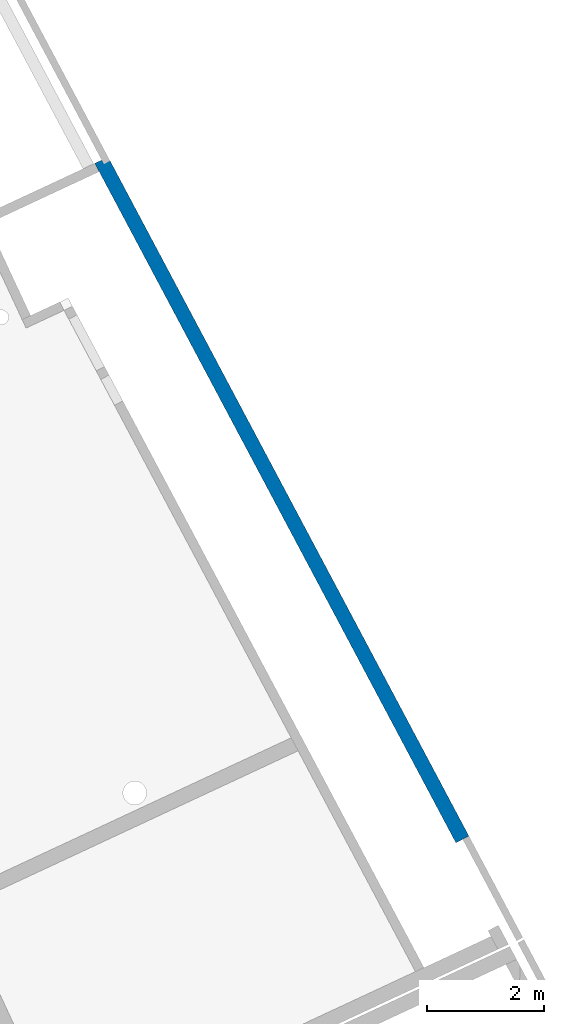
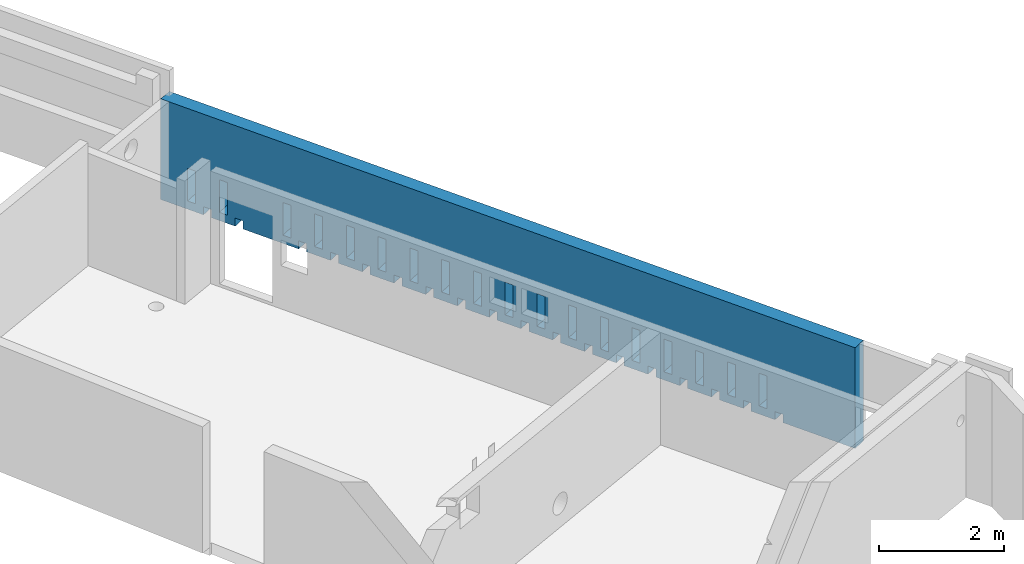
# One storey, part 12 of 13: 1 wall.
"""IFC2X3 building model written with IfcOpenShell, lengths in metres."""

import ifcopenshell
import ifcopenshell.guid

model = None  # the IFC model being written
_history = None  # IfcOwnerHistory: only IFC2X3 demands one
_inside = {}  # id of a spatial element -> (the spatial element, [elements in it])
_under = {}  # id of a project, library or spatial element -> (it, [spatial elements below it])
_declared = {}  # id of a project -> (the project, [libraries it declares])
_typed = {}  # id of a type object -> (the type object, [elements of that type])
_made_of = {}  # id of a material, layer set ... -> (it, [elements and type objects made of it])


def new_model(schema):
    """Start an empty IFC model of exactly this schema.

    Asked for "IFC4X3", IfcOpenShell would pick the latest addendum, in which some entities
    have other attributes; the version numbers below select the first issue.
    IFC2X3 requires an IfcOwnerHistory on every rooted entity: one is made here for all.
    """
    global model, _history
    if schema == "IFC4X3":
        model = ifcopenshell.file(schema_version=(4, 3, 0, 0))
    else:
        model = ifcopenshell.file(schema=schema)
    _inside.clear()
    _under.clear()
    _declared.clear()
    _typed.clear()
    _made_of.clear()
    _history = None
    if model.schema == "IFC2X3":
        org = make("IfcOrganization", Name="unknown")
        user = make(
            "IfcPersonAndOrganization",
            ThePerson=make("IfcPerson", FamilyName="unknown"),
            TheOrganization=org,
        )
        app = make(
            "IfcApplication",
            ApplicationDeveloper=org,
            Version="unknown",
            ApplicationFullName="unknown",
            ApplicationIdentifier="unknown",
        )
        _history = make(
            "IfcOwnerHistory",
            OwningUser=user,
            OwningApplication=app,
            ChangeAction="ADDED",
            CreationDate=0,
        )
    return model


def make(cls, **values):
    """One entity of the class cls with the attributes given. An attribute that is None is left unset."""
    return model.create_entity(
        cls, **{name: value for name, value in values.items() if value is not None}
    )


def entity(cls, *values):
    """Any entity or typed value of the class cls, its attributes in the order of the schema. None: left unset."""
    e = model.create_entity(cls)
    for i, value in enumerate(values):
        if value is not None:
            e[i] = value
    return e


def rooted(cls, **values):
    """An entity with a GlobalId (a new one), such as an element, a storey or a relation."""
    return make(cls, GlobalId=ifcopenshell.guid.new(), OwnerHistory=_history, **values)


def si_unit(unit_type, name, prefix=None):
    """IfcSIUnit, for example si_unit("LENGTHUNIT", "METRE", prefix="MILLI")."""
    return make("IfcSIUnit", UnitType=unit_type, Prefix=prefix, Name=name)


def converted_unit(unit_type, name, factor, base, dimensions=None, offset=None):
    """IfcConversionBasedUnit, such as the inch: factor (a typed value) times the base unit."""
    return make(
        "IfcConversionBasedUnit"
        if offset is None
        else "IfcConversionBasedUnitWithOffset",
        ConversionOffset=offset,
        Dimensions=None
        if dimensions is None
        else entity("IfcDimensionalExponents", *dimensions),
        UnitType=unit_type,
        Name=name,
        ConversionFactor=make(
            "IfcMeasureWithUnit", ValueComponent=factor, UnitComponent=base
        ),
    )


def derived_unit(unit_type, elements):
    """IfcDerivedUnit: a product of units, each with its exponent."""
    return make(
        "IfcDerivedUnit",
        Elements=[
            make("IfcDerivedUnitElement", Unit=unit, Exponent=power)
            for unit, power in elements
        ],
        UnitType=unit_type,
    )


def assignment(units):
    """IfcUnitAssignment: the units of a project."""
    return None if units is None else make("IfcUnitAssignment", Units=units)


def point(xyz):
    """IfcCartesianPoint."""
    return None if xyz is None else make("IfcCartesianPoint", Coordinates=xyz)


def direction(xyz):
    """IfcDirection."""
    return None if xyz is None else make("IfcDirection", DirectionRatios=xyz)


def frame(location, z_axis=None, x_axis=None):
    """IfcAxis2Placement3D, a coordinate frame: its origin and axes. An axis left out is left unset."""
    return make(
        "IfcAxis2Placement3D",
        Location=point(location),
        Axis=direction(z_axis),
        RefDirection=direction(x_axis),
    )


def origin():
    """The frame at (0, 0, 0) with its axes left unset."""
    return frame((0.0, 0.0, 0.0))


def place(relative_to, where):
    """IfcLocalPlacement: puts the frame where relative to a parent placement (None: the world)."""
    return make(
        "IfcLocalPlacement", PlacementRelTo=relative_to, RelativePlacement=where
    )


def context(
    kind, dimensions, precision=None, world=None, true_north=None, identifier=None
):
    """IfcGeometricRepresentationContext, for example the 3D "Model" context."""
    return make(
        "IfcGeometricRepresentationContext",
        ContextIdentifier=identifier,
        ContextType=kind,
        CoordinateSpaceDimension=dimensions,
        Precision=precision,
        WorldCoordinateSystem=world,
        TrueNorth=true_north,
    )


def subcontext(parent, identifier, kind, view, scale=None):
    """IfcGeometricRepresentationSubContext, for example "Body" below "Model"."""
    return make(
        "IfcGeometricRepresentationSubContext",
        ContextIdentifier=identifier,
        ContextType=kind,
        ParentContext=parent,
        TargetScale=scale,
        TargetView=view,
    )


def project(units=None, contexts=None):
    """IfcProject with its units and contexts."""
    return rooted(
        "IfcProject",
        Name="project",
        RepresentationContexts=contexts,
        UnitsInContext=assignment(units),
    )


def spatial(cls, under=None, at=None, **own):
    """A site, building, storey or space (cls), placed at a placement, below another one or the project."""
    s = rooted(cls, ObjectPlacement=at, **own)
    if under is not None:
        _under.setdefault(under.id(), (under, []))[1].append(s)
    return s


def faces_of(points, faces, orient=None, outer=None):
    """IfcFace entities. A face is a list of loops; a loop is a list of indices into points, from 0.

    orient and outer hold one flag for each loop. By default every Orientation is true, the
    first loop of a face is its IfcFaceOuterBound and the others are IfcFaceBound.
    """
    made = []
    for i, loops in enumerate(faces):
        bounds = []
        for j, loop in enumerate(loops):
            is_outer = j == 0 if outer is None else outer[i][j]
            bounds.append(
                make(
                    "IfcFaceOuterBound" if is_outer else "IfcFaceBound",
                    Bound=make("IfcPolyLoop", Polygon=[points[k] for k in loop]),
                    Orientation=True if orient is None else orient[i][j],
                )
            )
        made.append(make("IfcFace", Bounds=bounds))
    return made


def faceted_brep(points, faces, orient=None, outer=None, voids=None):
    """IfcFacetedBrep: a solid bounded by flat faces; with voids (closed shells), ...WithVoids."""
    shared = [point(p) for p in points]
    hull = make("IfcClosedShell", CfsFaces=faces_of(shared, faces, orient, outer))
    if voids is None:
        return make("IfcFacetedBrep", Outer=hull)
    return make(
        "IfcFacetedBrepWithVoids",
        Outer=hull,
        Voids=[
            make(cls, CfsFaces=faces_of(shared, fs, o, b)) for cls, fs, o, b in voids
        ],
    )


def shape(context_of_items, identifier, shape_type, items):
    """IfcShapeRepresentation: the items that make up one representation, for example the "Body"."""
    return make(
        "IfcShapeRepresentation",
        ContextOfItems=context_of_items,
        RepresentationIdentifier=identifier,
        RepresentationType=shape_type,
        Items=items,
    )


def material(Name=None, Category=None):
    """IfcMaterial."""
    return make("IfcMaterial", Name=Name, Category=Category)


def layer(
    of_material, thickness, ventilated=None, Name=None, Category=None, Priority=None
):
    """IfcMaterialLayer: one layer of a wall or slab, of a material (None: an air gap)."""
    return make(
        "IfcMaterialLayer",
        Material=of_material,
        LayerThickness=thickness,
        IsVentilated=ventilated,
        Name=Name,
        Category=Category,
        Priority=Priority,
    )


def layer_set(layers, Name=None):
    """IfcMaterialLayerSet."""
    return make("IfcMaterialLayerSet", MaterialLayers=layers, LayerSetName=Name)


def made_of(thing, what):
    """Note that an element or type object is made of a material, layer set ...; save() writes the relation."""
    if what is not None:
        _made_of.setdefault(what.id(), (what, []))[1].append(thing)
    return thing


def type_object(cls, material=None, **own):
    """A type object (cls), such as IfcWallType, which elements share."""
    return made_of(rooted(cls, **own), material)


def element(
    cls,
    number,
    at=None,
    inside=None,
    cuts=None,
    type_object=None,
    material=None,
    context=None,
    identifier="Body",
    shape_type=None,
    held_by="IfcProductDefinitionShape",
    body=None,
    shapes=None,
    **own,
):
    """One element of the class cls, such as IfcWall. Its Tag is "e" and its number.

    at: its placement. inside: the storey or other place that contains it. cuts: it is an
    opening in that element (IfcRelVoidsElement). A single representation is given by context,
    identifier, shape_type and body (its items); several are given by shapes. held_by: the class
    of the entity that holds the representations. save() writes the other relations.
    """
    e = rooted(cls, Tag="e%d" % number, ObjectPlacement=at, **own)
    if body is not None:
        shapes = [shape(context, identifier, shape_type, body)]
    if shapes is not None:
        e.Representation = make(held_by, Representations=shapes)
    if inside is not None:
        _inside.setdefault(inside.id(), (inside, []))[1].append(e)
    if cuts is not None:
        rooted(
            "IfcRelVoidsElement", RelatingBuildingElement=cuts, RelatedOpeningElement=e
        )
    if type_object is not None:
        _typed.setdefault(type_object.id(), (type_object, []))[1].append(e)
    return made_of(e, material)


def aggregate(whole, parts):
    """IfcRelAggregates: a whole, such as a stair, and the parts it consists of."""
    return rooted("IfcRelAggregates", RelatingObject=whole, RelatedObjects=parts)


def save(model, path):
    """Write the relations noted so far, then the file.

    IfcRelAggregates (storeys below a building ...), IfcRelContainedInSpatialStructure (elements
    in a storey), IfcRelDefinesByType, IfcRelAssociatesMaterial and IfcRelDeclares: one each for
    every whole, place, type object, material and project.
    """
    for whole, parts in _under.values():
        aggregate(whole, parts)
    for where, things in _inside.values():
        rooted(
            "IfcRelContainedInSpatialStructure",
            RelatedElements=things,
            RelatingStructure=where,
        )
    for kind, things in _typed.values():
        rooted("IfcRelDefinesByType", RelatedObjects=things, RelatingType=kind)
    for what, things in _made_of.values():
        rooted("IfcRelAssociatesMaterial", RelatedObjects=things, RelatingMaterial=what)
    for by, libraries in _declared.values():
        rooted("IfcRelDeclares", RelatingContext=by, RelatedDefinitions=libraries)
    model.write(path)


model = new_model("IFC2X3")

# Units and contexts
model_context = context("Model", 3, precision=1e-05, world=origin(), true_north=direction((6.12303176911189e-17, 1.0)))
body_context = subcontext(model_context, "Body", "Model", "MODEL_VIEW")
ifc_project = project(units=[si_unit("LENGTHUNIT", "METRE"), si_unit("AREAUNIT", "SQUARE_METRE"), si_unit("VOLUMEUNIT", "CUBIC_METRE"), converted_unit("PLANEANGLEUNIT", "DEGREE", entity("IfcRatioMeasure", 0.0174532925199433), si_unit("PLANEANGLEUNIT", "RADIAN"), dimensions=[0, 0, 0, 0, 0, 0, 0]), si_unit("MASSUNIT", "GRAM", prefix="KILO"), derived_unit("MASSDENSITYUNIT", [(si_unit("MASSUNIT", "GRAM", prefix="KILO"), 1), (si_unit("LENGTHUNIT", "METRE"), -3)]), si_unit("TIMEUNIT", "SECOND"), si_unit("FREQUENCYUNIT", "HERTZ"), si_unit("THERMODYNAMICTEMPERATUREUNIT", "DEGREE_CELSIUS"), derived_unit("THERMALTRANSMITTANCEUNIT", [(si_unit("MASSUNIT", "GRAM", prefix="KILO"), 1), (si_unit("THERMODYNAMICTEMPERATUREUNIT", "KELVIN"), -1), (si_unit("TIMEUNIT", "SECOND"), -3)]), derived_unit("VOLUMETRICFLOWRATEUNIT", [(si_unit("LENGTHUNIT", "METRE"), 3), (si_unit("TIMEUNIT", "SECOND"), -1)]), si_unit("ELECTRICCURRENTUNIT", "AMPERE"), si_unit("ELECTRICVOLTAGEUNIT", "VOLT"), si_unit("POWERUNIT", "WATT"), si_unit("FORCEUNIT", "NEWTON", prefix="KILO"), si_unit("ILLUMINANCEUNIT", "LUX"), si_unit("LUMINOUSFLUXUNIT", "LUMEN"), si_unit("LUMINOUSINTENSITYUNIT", "CANDELA"), derived_unit("USERDEFINED", [(si_unit("MASSUNIT", "GRAM", prefix="KILO"), -1), (si_unit("LENGTHUNIT", "METRE"), -2), (si_unit("TIMEUNIT", "SECOND"), 3), (si_unit("LUMINOUSFLUXUNIT", "LUMEN"), 1)]), derived_unit("LINEARVELOCITYUNIT", [(si_unit("LENGTHUNIT", "METRE"), 1), (si_unit("TIMEUNIT", "SECOND"), -1)]), si_unit("PRESSUREUNIT", "PASCAL"), derived_unit("USERDEFINED", [(si_unit("LENGTHUNIT", "METRE"), -2), (si_unit("MASSUNIT", "GRAM", prefix="KILO"), 1), (si_unit("TIMEUNIT", "SECOND"), -2)])], contexts=[model_context])

# Site, building, storey
site_placement = place(None, frame((5.36960000000003, 43.3158000000006, 0.0), z_axis=(0.0, 0.0, 1.0), x_axis=(-0.422618261740703, 0.906307787036648, 0.0)))
site = spatial("IfcSite", under=ifc_project, at=site_placement, CompositionType="ELEMENT")
building_placement = place(site_placement, origin())
building = spatial("IfcBuilding", under=site, at=building_placement, CompositionType="ELEMENT")
storey_placement = place(building_placement, frame((0.0, 0.0, 2.56)))
storey = spatial("IfcBuildingStorey", under=building, at=storey_placement, CompositionType="ELEMENT", Elevation=2.56)

# Wall
ifc_material = material(Name="C30/37 XS1")
ifc_layer = layer(ifc_material, 0.25)
ifc_layer_set = layer_set([ifc_layer])
wall_type = type_object("IfcWallType", PredefinedType="STANDARD", material=ifc_layer_set)
wall_placement = place(storey_placement, frame((22.3212803030831, 1.31624621228755, 0.0), z_axis=(0.0, 0.0, 1.0), x_axis=(0.998640817743407, 0.0521202181190781, 0.0)))
element("IfcWall", 1, at=wall_placement, inside=storey, type_object=wall_type, context=body_context, shape_type="Brep", body=[
    faceted_brep([(13.1112262227629, -0.125, 1.97), (0.0, -0.125, 1.97), (0.0, -0.125, 0.0), (1.36351429752506, -0.125, 0.0), (1.36351429752506, -0.125, 0.160000000000072), (1.5135142975257, -0.125, 0.160000000000072), (1.51351429752581, -0.125, 0.0), (1.96351429752604, -0.125, 0.0), (1.96351429752603, -0.125, 0.160000000000072), (2.11351429752657, -0.125, 0.160000000000072), (2.11351429752672, -0.125, 0.0), (2.56351429752711, -0.125, 0.0), (2.56351429752721, -0.125, 0.160000000000072), (2.71351429752696, -0.125, 0.160000000000072), (2.71351429752713, -0.125, 0.0), (3.163514297528, -0.125, 0.0), (3.16351429752808, -0.125, 0.160000000000055), (3.31351429752793, -0.125, 0.160000000000055), (3.31351429752811, -0.125, 0.0), (3.76351429752895, -0.125, 0.0), (3.76351429752895, -0.125, 0.160000000000055), (3.91351429752916, -0.125, 0.160000000000055), (3.91351429752929, -0.125, 0.0), (4.36351429752981, -0.125, 0.0), (4.36351429752981, -0.125, 0.160000000000055), (4.51351429753002, -0.125, 0.160000000000055), (4.51351429753019, -0.125, 0.0), (4.96351429752977, -0.125, 0.0), (4.96351429752977, -0.125, 0.160000000000055), (5.11351429753029, -0.125, 0.160000000000055), (5.11351429753051, -0.125, 0.0), (5.56351429753074, -0.125, 0.0), (5.56351429753074, -0.125, 0.160000000000055), (5.71351429753126, -0.125, 0.160000000000055), (5.71351429753135, -0.125, 0.0), (6.16351429753172, -0.125, 0.0), (6.16351429753171, -0.125, 0.160000000000055), (6.31351429753223, -0.125, 0.160000000000055), (6.31351429753234, -0.125, 0.0), (6.76351429753268, -0.125, 0.0), (6.76351429753268, -0.125, 0.160000000000055), (6.91351429753349, -0.125, 0.160000000000055), (6.91351429753368, -0.125, 0.0), (7.36351429753365, -0.125, 0.0), (7.36351429753365, -0.125, 0.160000000000055), (7.51351429753362, -0.125, 0.160000000000055), (7.51351429753375, -0.125, 0.0), (7.96351429753462, -0.125, 0.0), (7.96351429753462, -0.125, 0.160000000000055), (8.11351429753459, -0.125, 0.160000000000055), (8.11351429753474, -0.125, 0.0), (8.56351429753588, -0.125, 0.0), (8.56351429753587, -0.125, 0.160000000000055), (8.71351429753556, -0.125, 0.160000000000055), (8.71351429753571, -0.125, 0.0), (9.16351429753664, -0.125, 0.0), (9.16351429753674, -0.125, 0.160000000000055), (9.31351429753653, -0.125, 0.160000000000055), (9.3135142975367, -0.125, 0.0), (9.76351429753699, -0.125, 0.0), (9.76351429753698, -0.125, 0.160000000000055), (9.9135142975375, -0.125, 0.160000000000055), (9.91351429753768, -0.125, 0.0), (10.363514297538, -0.125, 0.0), (10.3635142975379, -0.125, 0.160000000000055), (10.5135142975387, -0.125, 0.160000000000055), (10.5135142975388, -0.125, 0.0), (11.5635142975382, -0.125, 0.0), (11.5635142975382, -0.125, 0.160000000000082), (11.7135142975382, -0.125, 0.160000000000082), (11.7135142975384, -0.125, 0.0), (12.1635142975391, -0.125, 0.0), (12.1635142975389, -0.125, 0.160000000000082), (12.3135142975392, -0.125, 0.160000000000082), (12.3135142975393, -0.125, 0.0), (13.1112262227629, -0.125, 0.0), (12.4637180675649, -0.125, 0.799999999999991), (12.6140604058233, -0.125, 0.799999999999991), (12.6140604058238, -0.125, 0.160000000000082), (12.463718067565, -0.125, 0.160000000000082), (11.8635142975384, -0.125, 0.79999999999999), (12.0135142975387, -0.125, 0.79999999999999), (12.013514297539, -0.125, 0.160000000000082), (11.863514297539, -0.125, 0.160000000000082), (10.6635142975384, -0.125, 0.799999999999965), (10.8135142975391, -0.125, 0.799999999999965), (10.8135142975398, -0.125, 0.160000000000055), (10.6635142975384, -0.125, 0.160000000000055), (10.0635142975375, -0.125, 0.79999999999996), (10.2135142975383, -0.125, 0.79999999999996), (10.2135142975387, -0.125, 0.160000000000055), (10.0635142975375, -0.125, 0.160000000000055), (9.46351429753649, -0.125, 0.799999999999958), (9.61351429753701, -0.125, 0.799999999999958), (9.61351429753772, -0.125, 0.160000000000055), (9.46351429753649, -0.125, 0.160000000000055), (8.8635142975363, -0.125, 0.799999999999956), (9.01351429753605, -0.125, 0.799999999999956), (9.0135142975367, -0.125, 0.160000000000055), (8.86351429753582, -0.125, 0.160000000000055), (8.2635142975351, -0.125, 0.799999999999954), (8.41351429753508, -0.125, 0.799999999999954), (8.41351429753568, -0.125, 0.160000000000055), (8.2635142975351, -0.125, 0.160000000000055), (7.66351429753414, -0.125, 0.799999999999951), (7.8135142975341, -0.125, 0.799999999999951), (7.81351429753466, -0.125, 0.160000000000055), (7.66351429753414, -0.125, 0.160000000000055), (7.06351429753317, -0.125, 0.799999999999949), (7.21351429753313, -0.125, 0.799999999999949), (7.21351429753363, -0.125, 0.160000000000055), (7.06351429753317, -0.125, 0.160000000000055), (6.46351429753219, -0.125, 0.799999999999947), (6.61351429753271, -0.125, 0.799999999999947), (6.61351429753317, -0.125, 0.160000000000055), (6.46351429753219, -0.125, 0.160000000000055), (5.86351429753122, -0.125, 0.799999999999945), (6.01351429753174, -0.125, 0.799999999999945), (6.01351429753215, -0.125, 0.160000000000055), (5.86351429753122, -0.125, 0.160000000000055), (5.26351429753025, -0.125, 0.799999999999943), (5.41351429753078, -0.125, 0.799999999999943), (5.41351429753112, -0.125, 0.160000000000055), (5.26351429753025, -0.125, 0.160000000000055), (4.66351429753062, -0.125, 0.799999999999941), (4.81351429753046, -0.125, 0.799999999999941), (4.81351429753121, -0.125, 0.160000000000055), (4.66351429753024, -0.125, 0.160000000000055), (4.06351429752938, -0.125, 0.799999999999938), (4.21351429752959, -0.125, 0.799999999999938), (4.21351429753019, -0.125, 0.160000000000055), (4.06351429752938, -0.125, 0.160000000000055), (3.46351429752852, -0.125, 0.799999999999936), (3.61351429752842, -0.125, 0.799999999999936), (3.61351429752917, -0.125, 0.160000000000055), (3.46351429752852, -0.125, 0.160000000000055), (2.86351429752765, -0.125, 0.799999999999934), (3.01351429752745, -0.125, 0.799999999999934), (3.01351429752814, -0.125, 0.160000000000055), (2.86351429752726, -0.125, 0.160000000000055), (2.26351429752678, -0.125, 0.799999999999932), (2.413514297527, -0.125, 0.799999999999932), (2.41351429752767, -0.125, 0.160000000000072), (2.26351429752624, -0.125, 0.160000000000072), (1.66351429752554, -0.125, 0.79999999999993), (1.81351429752613, -0.125, 0.79999999999993), (1.81351429752666, -0.125, 0.160000000000072), (1.66351429752554, -0.125, 0.160000000000072), (12.4637180675648, 0.125, 0.799999999999991), (12.463718067565, 0.125, 0.160000000000082), (12.6140604058238, 0.125, 0.160000000000082), (12.6140604058233, 0.125, 0.799999999999991), (12.3135142975392, 0.125, 0.160000000000082), (12.1635142975389, 0.125, 0.160000000000082), (12.1635142975391, 0.125, 0.0), (11.7135142975384, 0.125, 0.0), (11.7135142975382, 0.125, 0.160000000000082), (11.5635142975382, 0.125, 0.160000000000082), (11.5635142975382, 0.125, 0.0), (10.5135142975388, 0.125, 0.0), (10.5135142975387, 0.125, 0.160000000000055), (10.3635142975379, 0.125, 0.160000000000055), (10.3635142975379, 0.125, 0.0), (9.91351429753769, 0.125, 0.0), (9.91351429753749, 0.125, 0.160000000000055), (9.76351429753698, 0.125, 0.160000000000055), (9.76351429753698, 0.125, 0.0), (9.3135142975367, 0.125, 0.0), (9.31351429753652, 0.125, 0.160000000000055), (9.16351429753673, 0.125, 0.160000000000055), (9.16351429753663, 0.125, 0.0), (8.71351429753571, 0.125, 0.0), (8.71351429753555, 0.125, 0.160000000000055), (8.56351429753587, 0.125, 0.160000000000055), (8.56351429753587, 0.125, 0.0), (8.11351429753474, 0.125, 0.0), (8.11351429753458, 0.125, 0.160000000000055), (7.96351429753461, 0.125, 0.160000000000055), (7.96351429753461, 0.125, 0.0), (7.51351429753375, 0.125, 0.0), (7.51351429753361, 0.125, 0.160000000000055), (7.36351429753364, 0.125, 0.160000000000055), (7.36351429753364, 0.125, 0.0), (6.91351429753369, 0.125, 0.0), (6.91351429753349, 0.125, 0.160000000000055), (6.76351429753268, 0.125, 0.160000000000055), (6.76351429753268, 0.125, 0.0), (6.31351429753234, 0.125, 0.0), (6.31351429753223, 0.125, 0.160000000000055), (6.16351429753171, 0.125, 0.160000000000055), (6.16351429753171, 0.125, 0.0), (5.71351429753135, 0.125, 0.0), (5.71351429753125, 0.125, 0.160000000000055), (5.56351429753073, 0.125, 0.160000000000055), (5.56351429753073, 0.125, 0.0), (5.11351429753051, 0.125, 0.0), (5.11351429753028, 0.125, 0.160000000000055), (4.96351429752976, 0.125, 0.160000000000055), (4.96351429752976, 0.125, 0.0), (4.51351429753019, 0.125, 0.0), (4.51351429753002, 0.125, 0.160000000000055), (4.3635142975298, 0.125, 0.160000000000055), (4.3635142975298, 0.125, 0.0), (3.91351429752929, 0.125, 0.0), (3.91351429752915, 0.125, 0.160000000000055), (3.76351429752894, 0.125, 0.160000000000055), (3.76351429752894, 0.125, 0.0), (3.31351429752811, 0.125, 0.0), (3.31351429752793, 0.125, 0.160000000000055), (3.16351429752807, 0.125, 0.160000000000055), (3.16351429752799, 0.125, 0.0), (2.71351429752713, 0.125, 0.0), (2.71351429752696, 0.125, 0.160000000000072), (2.56351429752721, 0.125, 0.160000000000072), (2.5635142975271, 0.125, 0.0), (2.11351429752672, 0.125, 0.0), (2.11351429752656, 0.125, 0.160000000000072), (1.96351429752602, 0.125, 0.160000000000072), (1.96351429752602, 0.125, 0.0), (1.51351429752581, 0.125, 0.0), (1.51351429752569, 0.125, 0.160000000000072), (1.36351429752505, 0.125, 0.160000000000072), (1.36351429752505, 0.125, 0.0), (0.0, 0.125, 0.0), (0.0, 0.125, 1.97), (12.9640562464722, 0.125, 1.97), (13.1242740116158, 0.125, 1.97), (13.1242740116158, 0.125, 0.0), (12.3135142975393, 0.125, 0.0), (11.8635142975384, 0.125, 0.79999999999999), (11.863514297539, 0.125, 0.160000000000082), (12.013514297539, 0.125, 0.160000000000082), (12.0135142975387, 0.125, 0.79999999999999), (10.6635142975384, 0.125, 0.799999999999965), (10.6635142975384, 0.125, 0.160000000000055), (10.8135142975398, 0.125, 0.160000000000055), (10.8135142975391, 0.125, 0.799999999999965), (10.0635142975375, 0.125, 0.79999999999996), (10.0635142975375, 0.125, 0.160000000000055), (10.2135142975387, 0.125, 0.160000000000055), (10.2135142975382, 0.125, 0.79999999999996), (9.46351429753649, 0.125, 0.799999999999958), (9.46351429753649, 0.125, 0.160000000000055), (9.61351429753772, 0.125, 0.160000000000055), (9.61351429753701, 0.125, 0.799999999999958), (8.8635142975363, 0.125, 0.799999999999956), (8.86351429753581, 0.125, 0.160000000000055), (9.0135142975367, 0.125, 0.160000000000055), (9.01351429753604, 0.125, 0.799999999999956), (8.2635142975351, 0.125, 0.799999999999954), (8.2635142975351, 0.125, 0.160000000000055), (8.41351429753567, 0.125, 0.160000000000055), (8.41351429753507, 0.125, 0.799999999999954), (7.66351429753413, 0.125, 0.799999999999951), (7.66351429753413, 0.125, 0.160000000000055), (7.81351429753466, 0.125, 0.160000000000055), (7.8135142975341, 0.125, 0.799999999999951), (7.06351429753316, 0.125, 0.799999999999949), (7.06351429753316, 0.125, 0.160000000000055), (7.21351429753363, 0.125, 0.160000000000055), (7.21351429753312, 0.125, 0.799999999999949), (6.46351429753219, 0.125, 0.799999999999947), (6.46351429753219, 0.125, 0.160000000000055), (6.61351429753316, 0.125, 0.160000000000055), (6.61351429753271, 0.125, 0.799999999999947), (5.86351429753122, 0.125, 0.799999999999945), (5.86351429753122, 0.125, 0.160000000000055), (6.01351429753214, 0.125, 0.160000000000055), (6.01351429753174, 0.125, 0.799999999999945), (5.26351429753025, 0.125, 0.799999999999943), (5.26351429753025, 0.125, 0.160000000000055), (5.41351429753112, 0.125, 0.160000000000055), (5.41351429753078, 0.125, 0.799999999999943), (4.66351429753061, 0.125, 0.799999999999941), (4.66351429753024, 0.125, 0.160000000000055), (4.81351429753121, 0.125, 0.160000000000055), (4.81351429753046, 0.125, 0.799999999999941), (4.06351429752937, 0.125, 0.799999999999938), (4.06351429752937, 0.125, 0.160000000000055), (4.21351429753019, 0.125, 0.160000000000055), (4.21351429752959, 0.125, 0.799999999999938), (3.46351429752851, 0.125, 0.799999999999936), (3.46351429752851, 0.125, 0.160000000000055), (3.61351429752917, 0.125, 0.160000000000055), (3.61351429752841, 0.125, 0.799999999999936), (2.86351429752764, 0.125, 0.799999999999934), (2.86351429752725, 0.125, 0.160000000000055), (3.01351429752814, 0.125, 0.160000000000055), (3.01351429752744, 0.125, 0.799999999999934), (2.26351429752678, 0.125, 0.799999999999932), (2.26351429752624, 0.125, 0.160000000000072), (2.41351429752767, 0.125, 0.160000000000072), (2.41351429752699, 0.125, 0.799999999999932), (1.66351429752554, 0.125, 0.79999999999993), (1.66351429752554, 0.125, 0.160000000000072), (1.81351429752666, 0.125, 0.160000000000072), (1.81351429752613, 0.125, 0.79999999999993), (0.0, -0.00499999999987975, 1.97)], [[[0, 1, 2, 3, 4, 5, 6, 7, 8, 9, 10, 11, 12, 13, 14, 15, 16, 17, 18, 19, 20, 21, 22, 23, 24, 25, 26, 27, 28, 29, 30, 31, 32, 33, 34, 35, 36, 37, 38, 39, 40, 41, 42, 43, 44, 45, 46, 47, 48, 49, 50, 51, 52, 53, 54, 55, 56, 57, 58, 59, 60, 61, 62, 63, 64, 65, 66, 67, 68, 69, 70, 71, 72, 73, 74, 75], [76, 77, 78, 79], [80, 81, 82, 83], [84, 85, 86, 87], [88, 89, 90, 91], [92, 93, 94, 95], [96, 97, 98, 99], [100, 101, 102, 103], [104, 105, 106, 107], [108, 109, 110, 111], [112, 113, 114, 115], [116, 117, 118, 119], [120, 121, 122, 123], [124, 125, 126, 127], [128, 129, 130, 131], [132, 133, 134, 135], [136, 137, 138, 139], [140, 141, 142, 143], [144, 145, 146, 147]], [[148, 149, 150, 151], [152, 153, 154, 155, 156, 157, 158, 159, 160, 161, 162, 163, 164, 165, 166, 167, 168, 169, 170, 171, 172, 173, 174, 175, 176, 177, 178, 179, 180, 181, 182, 183, 184, 185, 186, 187, 188, 189, 190, 191, 192, 193, 194, 195, 196, 197, 198, 199, 200, 201, 202, 203, 204, 205, 206, 207, 208, 209, 210, 211, 212, 213, 214, 215, 216, 217, 218, 219, 220, 221, 222, 223, 224, 225, 226, 227, 228], [229, 230, 231, 232], [233, 234, 235, 236], [237, 238, 239, 240], [241, 242, 243, 244], [245, 246, 247, 248], [249, 250, 251, 252], [253, 254, 255, 256], [257, 258, 259, 260], [261, 262, 263, 264], [265, 266, 267, 268], [269, 270, 271, 272], [273, 274, 275, 276], [277, 278, 279, 280], [281, 282, 283, 284], [285, 286, 287, 288], [289, 290, 291, 292], [293, 294, 295, 296]], [[1, 0, 226, 225, 224, 297]], [[297, 224, 223, 2, 1]], [[77, 76, 148, 151]], [[78, 77, 151, 150]], [[79, 78, 150, 149]], [[76, 79, 149, 148]], [[73, 72, 153, 152]], [[73, 152, 228, 74]], [[153, 72, 71, 154]], [[81, 80, 229, 232]], [[82, 81, 232, 231]], [[83, 82, 231, 230]], [[80, 83, 230, 229]], [[69, 68, 157, 156]], [[69, 156, 155, 70]], [[157, 68, 67, 158]], [[85, 84, 233, 236]], [[86, 85, 236, 235]], [[87, 86, 235, 234]], [[84, 87, 234, 233]], [[65, 64, 161, 160]], [[65, 160, 159, 66]], [[161, 64, 63, 162]], [[89, 88, 237, 240]], [[90, 89, 240, 239]], [[91, 90, 239, 238]], [[88, 91, 238, 237]], [[61, 60, 165, 164]], [[61, 164, 163, 62]], [[165, 60, 59, 166]], [[93, 92, 241, 244]], [[94, 93, 244, 243]], [[95, 94, 243, 242]], [[92, 95, 242, 241]], [[57, 56, 169, 168]], [[57, 168, 167, 58]], [[169, 56, 55, 170]], [[97, 96, 245, 248]], [[98, 97, 248, 247]], [[99, 98, 247, 246]], [[96, 99, 246, 245]], [[53, 52, 173, 172]], [[53, 172, 171, 54]], [[173, 52, 51, 174]], [[101, 100, 249, 252]], [[102, 101, 252, 251]], [[103, 102, 251, 250]], [[100, 103, 250, 249]], [[49, 48, 177, 176]], [[49, 176, 175, 50]], [[177, 48, 47, 178]], [[105, 104, 253, 256]], [[106, 105, 256, 255]], [[107, 106, 255, 254]], [[104, 107, 254, 253]], [[45, 44, 181, 180]], [[45, 180, 179, 46]], [[181, 44, 43, 182]], [[109, 108, 257, 260]], [[110, 109, 260, 259]], [[111, 110, 259, 258]], [[108, 111, 258, 257]], [[41, 40, 185, 184]], [[41, 184, 183, 42]], [[185, 40, 39, 186]], [[113, 112, 261, 264]], [[114, 113, 264, 263]], [[115, 114, 263, 262]], [[112, 115, 262, 261]], [[37, 36, 189, 188]], [[37, 188, 187, 38]], [[189, 36, 35, 190]], [[117, 116, 265, 268]], [[118, 117, 268, 267]], [[119, 118, 267, 266]], [[116, 119, 266, 265]], [[33, 32, 193, 192]], [[33, 192, 191, 34]], [[193, 32, 31, 194]], [[121, 120, 269, 272]], [[122, 121, 272, 271]], [[123, 122, 271, 270]], [[120, 123, 270, 269]], [[29, 28, 197, 196]], [[29, 196, 195, 30]], [[197, 28, 27, 198]], [[125, 124, 273, 276]], [[126, 125, 276, 275]], [[127, 126, 275, 274]], [[124, 127, 274, 273]], [[25, 24, 201, 200]], [[25, 200, 199, 26]], [[201, 24, 23, 202]], [[129, 128, 277, 280]], [[130, 129, 280, 279]], [[131, 130, 279, 278]], [[128, 131, 278, 277]], [[21, 20, 205, 204]], [[21, 204, 203, 22]], [[205, 20, 19, 206]], [[133, 132, 281, 284]], [[134, 133, 284, 283]], [[135, 134, 283, 282]], [[132, 135, 282, 281]], [[17, 16, 209, 208]], [[17, 208, 207, 18]], [[209, 16, 15, 210]], [[137, 136, 285, 288]], [[138, 137, 288, 287]], [[139, 138, 287, 286]], [[136, 139, 286, 285]], [[13, 12, 213, 212]], [[13, 212, 211, 14]], [[213, 12, 11, 214]], [[141, 140, 289, 292]], [[142, 141, 292, 291]], [[143, 142, 291, 290]], [[140, 143, 290, 289]], [[9, 8, 217, 216]], [[9, 216, 215, 10]], [[217, 8, 7, 218]], [[145, 144, 293, 296]], [[146, 145, 296, 295]], [[147, 146, 295, 294]], [[144, 147, 294, 293]], [[5, 4, 221, 220]], [[5, 220, 219, 6]], [[221, 4, 3, 222]], [[226, 0, 75, 227]], [[75, 74, 228, 227]], [[71, 70, 155, 154]], [[67, 66, 159, 158]], [[63, 62, 163, 162]], [[59, 58, 167, 166]], [[55, 54, 171, 170]], [[51, 50, 175, 174]], [[47, 46, 179, 178]], [[43, 42, 183, 182]], [[39, 38, 187, 186]], [[35, 34, 191, 190]], [[31, 30, 195, 194]], [[27, 26, 199, 198]], [[23, 22, 203, 202]], [[19, 18, 207, 206]], [[15, 14, 211, 210]], [[11, 10, 215, 214]], [[7, 6, 219, 218]], [[3, 2, 223, 222]]], outer=[[True, False, False, False, False, False, False, False, False, False, False, False, False, False, False, False, False, False, False], [False, True, False, False, False, False, False, False, False, False, False, False, False, False, False, False, False, False, False], [True], [True], [True], [True], [True], [True], [True], [True], [True], [True], [True], [True], [True], [True], [True], [True], [True], [True], [True], [True], [True], [True], [True], [True], [True], [True], [True], [True], [True], [True], [True], [True], [True], [True], [True], [True], [True], [True], [True], [True], [True], [True], [True], [True], [True], [True], [True], [True], [True], [True], [True], [True], [True], [True], [True], [True], [True], [True], [True], [True], [True], [True], [True], [True], [True], [True], [True], [True], [True], [True], [True], [True], [True], [True], [True], [True], [True], [True], [True], [True], [True], [True], [True], [True], [True], [True], [True], [True], [True], [True], [True], [True], [True], [True], [True], [True], [True], [True], [True], [True], [True], [True], [True], [True], [True], [True], [True], [True], [True], [True], [True], [True], [True], [True], [True], [True], [True], [True], [True], [True], [True], [True], [True], [True], [True], [True], [True], [True], [True], [True], [True], [True], [True], [True], [True], [True], [True], [True], [True], [True], [True], [True], [True], [True], [True], [True], [True], [True]]),
])

save(model, "model.ifc")
